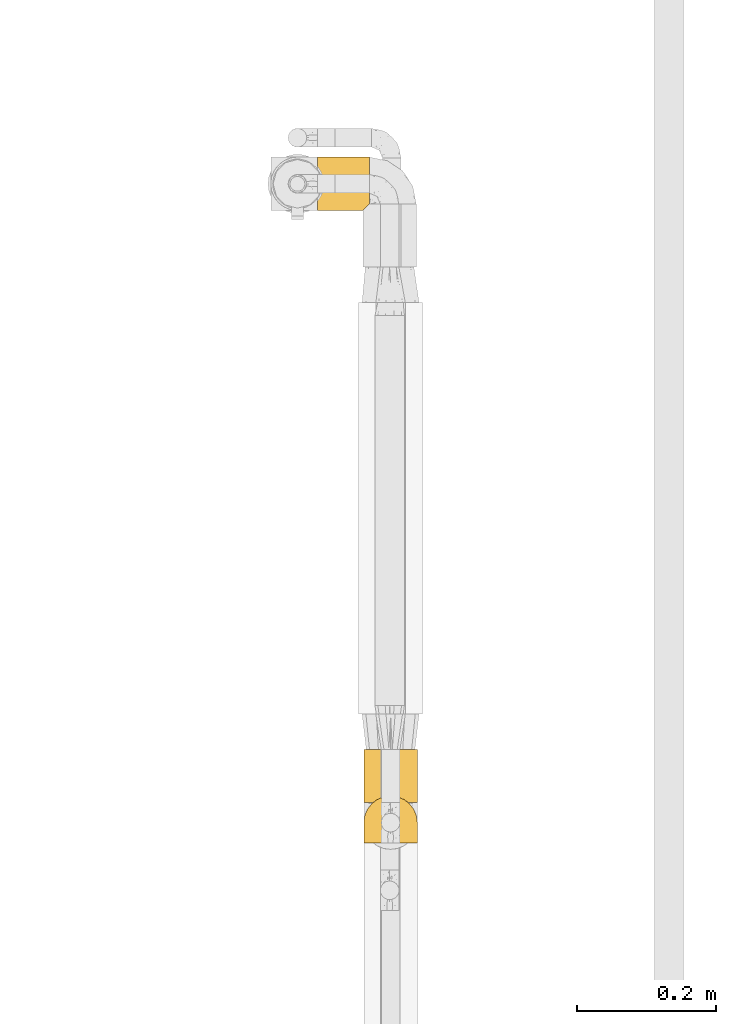
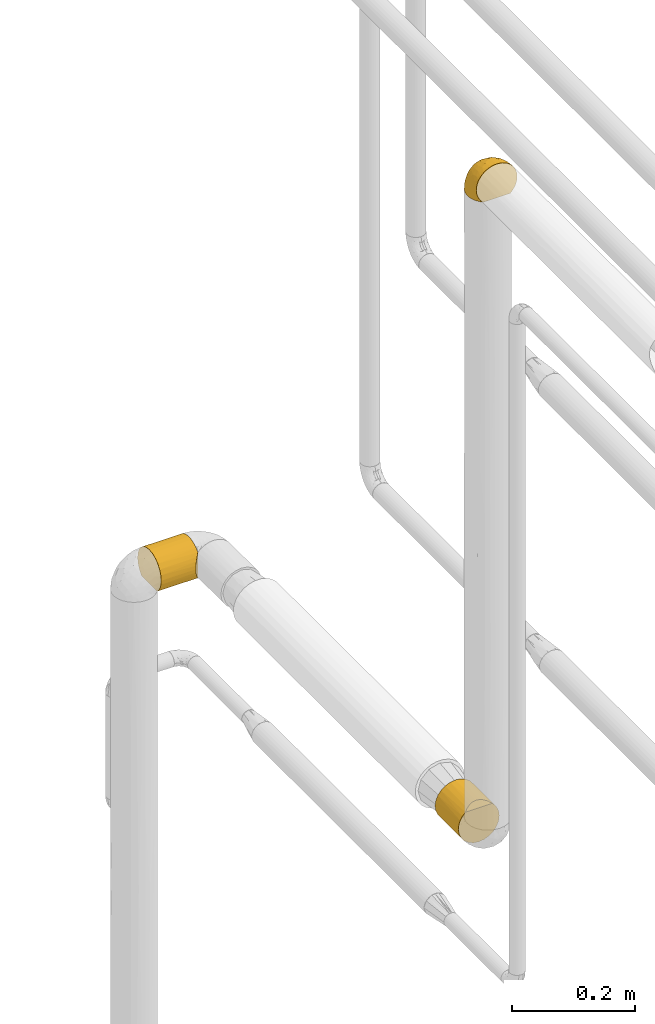
# One storey, part 65 of 827: 3 coverings.
"""IFC2X3 building model written with IfcOpenShell, lengths in millimetres."""

from ifc_helpers import new_model, entity, si_unit, converted_unit, derived_unit, direction, frame, origin, place, context, subcontext, project, spatial, faceted_brep, element, save


model = new_model("IFC2X3")

# Units and contexts
model_context = context("Model", 3, precision=0.01, world=origin(), true_north=direction((6.12303176911189e-17, 1.0)))
body_context = subcontext(model_context, "Body", "Model", "MODEL_VIEW")
ifc_project = project(units=[si_unit("LENGTHUNIT", "METRE", prefix="MILLI"), si_unit("AREAUNIT", "SQUARE_METRE"), si_unit("VOLUMEUNIT", "CUBIC_METRE"), converted_unit("PLANEANGLEUNIT", "DEGREE", entity("IfcRatioMeasure", 0.0174532925199433), si_unit("PLANEANGLEUNIT", "RADIAN"), dimensions=[0, 0, 0, 0, 0, 0, 0]), si_unit("MASSUNIT", "GRAM", prefix="KILO"), derived_unit("MASSDENSITYUNIT", [(si_unit("MASSUNIT", "GRAM", prefix="KILO"), 1), (si_unit("LENGTHUNIT", "METRE"), -3)]), derived_unit("MOMENTOFINERTIAUNIT", [(si_unit("LENGTHUNIT", "METRE"), 4)]), si_unit("TIMEUNIT", "SECOND"), si_unit("FREQUENCYUNIT", "HERTZ"), si_unit("THERMODYNAMICTEMPERATUREUNIT", "DEGREE_CELSIUS"), derived_unit("THERMALTRANSMITTANCEUNIT", [(si_unit("MASSUNIT", "GRAM", prefix="KILO"), 1), (si_unit("THERMODYNAMICTEMPERATUREUNIT", "KELVIN"), -1), (si_unit("TIMEUNIT", "SECOND"), -3)]), derived_unit("VOLUMETRICFLOWRATEUNIT", [(si_unit("LENGTHUNIT", "METRE"), 3), (si_unit("TIMEUNIT", "SECOND"), -1)]), derived_unit("MASSFLOWRATEUNIT", [(si_unit("MASSUNIT", "GRAM", prefix="KILO"), 1), (si_unit("TIMEUNIT", "SECOND"), -1)]), derived_unit("ROTATIONALFREQUENCYUNIT", [(si_unit("TIMEUNIT", "SECOND"), -1)]), si_unit("ELECTRICCURRENTUNIT", "AMPERE"), si_unit("ELECTRICVOLTAGEUNIT", "VOLT"), si_unit("POWERUNIT", "WATT"), si_unit("FORCEUNIT", "NEWTON", prefix="KILO"), si_unit("ILLUMINANCEUNIT", "LUX"), si_unit("LUMINOUSFLUXUNIT", "LUMEN"), si_unit("LUMINOUSINTENSITYUNIT", "CANDELA"), derived_unit("USERDEFINED", [(si_unit("MASSUNIT", "GRAM", prefix="KILO"), -1), (si_unit("LENGTHUNIT", "METRE"), -2), (si_unit("TIMEUNIT", "SECOND"), 3), (si_unit("LUMINOUSFLUXUNIT", "LUMEN"), 1)]), derived_unit("LINEARVELOCITYUNIT", [(si_unit("LENGTHUNIT", "METRE"), 1), (si_unit("TIMEUNIT", "SECOND"), -1)]), si_unit("PRESSUREUNIT", "PASCAL"), derived_unit("USERDEFINED", [(si_unit("LENGTHUNIT", "METRE"), -2), (si_unit("MASSUNIT", "GRAM", prefix="KILO"), 1), (si_unit("TIMEUNIT", "SECOND"), -2)]), derived_unit("LINEARFORCEUNIT", [(si_unit("MASSUNIT", "GRAM", prefix="KILO"), 1), (si_unit("LENGTHUNIT", "METRE"), 1), (si_unit("TIMEUNIT", "SECOND"), -2), (si_unit("LENGTHUNIT", "METRE"), -1)]), derived_unit("PLANARFORCEUNIT", [(si_unit("MASSUNIT", "GRAM", prefix="KILO"), 1), (si_unit("LENGTHUNIT", "METRE"), 1), (si_unit("TIMEUNIT", "SECOND"), -2), (si_unit("LENGTHUNIT", "METRE"), -2)])], contexts=[model_context])

# Site, building, storey
site_placement = place(None, origin())
site = spatial("IfcSite", under=ifc_project, at=site_placement, CompositionType="ELEMENT")
building_placement = place(site_placement, origin())
building = spatial("IfcBuilding", under=site, at=building_placement, CompositionType="ELEMENT")
storey_placement = place(building_placement, frame((0.0, 0.0, 28200.0)))
storey = spatial("IfcBuildingStorey", under=building, at=storey_placement, Name="08", CompositionType="ELEMENT", Elevation=28200.0)

# Coverings
covering_1_placement = place(storey_placement, frame((15160.93, 11287.8, 1505.75)))
element("IfcCovering", 1, at=covering_1_placement, inside=storey, Name=":ADSK_", ObjectType=":ADSK_", PredefinedType="INSULATION", context=body_context, shape_type="Brep", body=[
    faceted_brep([(20.8, 1.6, 6.74), (30.06, 1.6, 2.9), (40.0, 1.6, 1.6), (49.93, 1.6, 2.9), (59.2, 1.6, 6.74), (67.15, 1.6, 12.84), (73.25, 1.6, 20.8), (77.09, 1.6, 30.06), (78.4, 1.6, 40.0), (77.51, 1.6, 48.2), (74.9, 1.6, 56.01), (70.68, 1.6, 63.08), (65.05, 1.6, 69.1), (14.94, 1.6, 69.1), (9.31, 1.6, 63.08), (5.09, 1.6, 56.01), (2.48, 1.6, 48.2), (1.6, 1.6, 40.0), (2.9, 1.6, 30.06), (6.74, 1.6, 20.8), (12.84, 1.6, 12.84), (20.8, 77.5, 6.74), (12.84, 77.5, 12.84), (6.74, 77.5, 20.8), (2.9, 77.5, 30.06), (1.6, 77.5, 40.0), (2.9, 77.5, 49.93), (6.74, 77.5, 59.2), (12.84, 77.5, 67.15), (20.8, 77.5, 73.25), (30.06, 77.5, 77.09), (40.0, 77.5, 78.4), (49.93, 77.5, 77.09), (59.2, 77.5, 73.25), (67.15, 77.5, 67.15), (73.25, 77.5, 59.2), (77.09, 77.5, 49.93), (78.4, 77.5, 40.0), (77.09, 77.5, 30.06), (73.25, 77.5, 20.8), (67.15, 77.5, 12.84), (59.2, 77.5, 6.74), (49.93, 77.5, 2.9), (40.0, 77.5, 1.6), (30.06, 77.5, 2.9), (53.36, 8.5, 76.0), (46.78, 10.29, 77.79), (40.0, 10.9, 78.4), (59.51, 5.57, 73.07), (33.21, 10.29, 77.79), (26.63, 8.5, 76.0), (20.48, 5.57, 73.07)], [[[0, 1, 2, 3, 4, 5, 6, 7, 8, 9, 10, 11, 12, 13, 14, 15, 16, 17, 18, 19, 20]], [[21, 22, 23, 24, 25, 26, 27, 28, 29, 30, 31, 32, 33, 34, 35, 36, 37, 38, 39, 40, 41, 42, 43, 44]], [[24, 23, 19, 18]], [[25, 24, 18, 17]], [[20, 19, 23, 22]], [[1, 0, 21, 44]], [[2, 1, 44, 43]], [[22, 21, 0, 20]], [[3, 2, 43, 42]], [[4, 3, 42, 41]], [[41, 40, 5, 4]], [[7, 6, 39, 38]], [[8, 7, 38, 37]], [[40, 39, 6, 5]], [[9, 37, 36]], [[10, 36, 35]], [[11, 35, 34]], [[8, 37, 9]], [[9, 36, 10]], [[35, 11, 10]], [[34, 12, 11]], [[45, 33, 32]], [[32, 31, 46]], [[47, 46, 31]], [[48, 12, 33]], [[46, 45, 32]], [[48, 33, 45]], [[33, 12, 34]], [[49, 47, 31]], [[49, 31, 30]], [[50, 30, 29]], [[50, 49, 30]], [[13, 51, 29]], [[50, 29, 51]], [[29, 28, 13]], [[14, 28, 27]], [[15, 27, 26]], [[16, 26, 25]], [[14, 27, 15]], [[15, 26, 16]], [[25, 17, 16]], [[28, 14, 13]], [[45, 46, 47, 49, 50, 51, 13, 12, 48]]]),
])
covering_2_placement = place(storey_placement, frame((15094.48, 12139.43, 1505.75)))
element("IfcCovering", 2, at=covering_2_placement, inside=storey, Name=":ADSK_", ObjectType=":ADSK_", PredefinedType="INSULATION", context=body_context, shape_type="Brep", body=[
    faceted_brep([(1.6, 2.48, 31.79), (1.6, 1.6, 40.0), (1.6, 2.9, 49.93), (1.6, 6.74, 59.2), (1.6, 12.84, 67.15), (1.6, 20.8, 73.25), (1.6, 30.06, 77.09), (1.6, 40.0, 78.4), (1.6, 49.93, 77.09), (1.6, 59.2, 73.25), (1.6, 67.15, 67.15), (1.6, 73.25, 59.2), (1.6, 77.09, 49.93), (1.6, 78.4, 40.0), (1.6, 77.51, 31.79), (1.6, 74.9, 23.98), (1.6, 70.68, 16.91), (1.6, 65.05, 10.9), (1.6, 14.94, 10.9), (1.6, 9.31, 16.91), (1.6, 5.09, 23.98), (75.9, 10.9, 14.94), (75.9, 16.91, 9.31), (75.9, 23.98, 5.09), (75.9, 31.79, 2.48), (75.9, 40.0, 1.6), (75.9, 49.93, 2.9), (75.9, 59.2, 6.74), (75.9, 67.15, 12.84), (75.9, 73.25, 20.8), (75.9, 77.09, 30.06), (75.9, 78.4, 40.0), (75.9, 77.09, 49.93), (75.9, 73.25, 59.2), (75.9, 67.15, 67.15), (75.9, 59.2, 73.25), (75.9, 49.93, 77.09), (75.9, 40.0, 78.4), (75.9, 31.79, 77.51), (75.9, 23.98, 74.9), (75.9, 16.91, 70.68), (75.9, 10.9, 65.05), (8.5, 53.36, 4.0), (10.29, 46.78, 2.2), (10.9, 40.0, 1.6), (5.57, 59.51, 6.92), (10.29, 33.21, 2.2), (8.5, 26.63, 4.0), (5.57, 20.48, 6.92), (71.92, 6.92, 20.48), (69.0, 4.0, 26.63), (67.2, 2.2, 33.21), (66.6, 1.6, 40.0), (67.2, 2.2, 46.78), (69.0, 4.0, 53.36), (71.92, 6.92, 59.51)], [[[0, 1, 2, 3, 4, 5, 6, 7, 8, 9, 10, 11, 12, 13, 14, 15, 16, 17, 18, 19, 20]], [[21, 22, 23, 24, 25, 26, 27, 28, 29, 30, 31, 32, 33, 34, 35, 36, 37, 38, 39, 40, 41]], [[31, 30, 14]], [[29, 28, 16]], [[30, 29, 15]], [[13, 31, 14]], [[16, 15, 29]], [[30, 15, 14]], [[28, 17, 16]], [[42, 27, 26]], [[26, 25, 43]], [[44, 43, 25]], [[45, 17, 27]], [[43, 42, 26]], [[45, 27, 42]], [[27, 17, 28]], [[46, 25, 24]], [[47, 24, 23]], [[48, 23, 22]], [[46, 44, 25]], [[48, 47, 23]], [[18, 48, 22]], [[46, 24, 47]], [[22, 21, 18]], [[21, 49, 19]], [[50, 51, 0]], [[49, 50, 20]], [[19, 49, 20]], [[51, 1, 0]], [[0, 20, 50]], [[1, 51, 52]], [[21, 19, 18]], [[53, 54, 2]], [[55, 41, 3]], [[54, 55, 3]], [[52, 53, 1]], [[1, 53, 2]], [[54, 3, 2]], [[41, 4, 3]], [[5, 40, 39]], [[6, 39, 38]], [[7, 38, 37]], [[4, 40, 5]], [[5, 39, 6]], [[38, 7, 6]], [[40, 4, 41]], [[8, 7, 37, 36]], [[9, 8, 36, 35]], [[35, 34, 10, 9]], [[12, 11, 33, 32]], [[13, 12, 32, 31]], [[34, 33, 11, 10]], [[17, 45, 42, 43, 44, 46, 47, 48, 18]], [[51, 50, 49, 21, 41, 55, 54, 53, 52]]]),
])
covering_3_placement = place(storey_placement, frame((15160.88, 11229.61, 2819.46)))
element("IfcCovering", 3, at=covering_3_placement, inside=storey, Name=":ADSK_", ObjectType=":ADSK_", PredefinedType="INSULATION", context=body_context, shape_type="Brep", body=[
    faceted_brep([(74.68, 1.6, 47.38), (70.1, 1.6, 54.67), (64.01, 1.6, 60.76), (56.72, 1.6, 65.34), (48.6, 1.6, 68.18), (40.05, 1.6, 69.15), (31.49, 1.6, 68.18), (23.36, 1.6, 65.33), (16.07, 1.6, 60.75), (9.98, 1.6, 54.66), (5.4, 1.6, 47.37), (2.56, 1.6, 39.25), (1.6, 1.6, 30.7), (2.46, 1.6, 22.59), (5.01, 1.6, 14.86), (9.13, 1.6, 7.84), (14.62, 1.6, 1.85), (16.82, 1.6, 1.85), (18.56, 1.6, 1.85), (20.52, 1.6, 1.85), (22.49, 1.6, 1.85), (24.46, 1.6, 1.85), (26.42, 1.6, 1.85), (28.39, 1.6, 1.85), (30.36, 1.6, 1.85), (32.55, 1.6, 1.85), (34.75, 1.6, 1.85), (36.94, 1.6, 1.85), (39.13, 1.6, 1.85), (41.33, 1.6, 1.85), (43.52, 1.6, 1.85), (45.72, 1.6, 1.85), (47.91, 1.6, 1.85), (50.11, 1.6, 1.85), (52.3, 1.6, 1.85), (54.49, 1.6, 1.85), (56.69, 1.6, 1.85), (58.88, 1.6, 1.85), (61.08, 1.6, 1.85), (63.27, 1.6, 1.85), (65.47, 1.6, 1.85), (70.97, 1.6, 7.85), (75.09, 1.6, 14.88), (77.64, 1.6, 22.61), (78.5, 1.6, 30.7), (77.53, 1.6, 39.26), (14.62, 1.85, 1.6), (9.12, 7.85, 1.6), (5.0, 14.87, 1.6), (2.46, 22.6, 1.6), (1.6, 30.7, 1.6), (2.91, 40.65, 1.6), (6.75, 49.92, 1.6), (12.86, 57.89, 1.6), (20.82, 64.0, 1.6), (30.09, 67.84, 1.6), (40.05, 69.15, 1.6), (50.0, 67.84, 1.6), (59.27, 64.0, 1.6), (67.23, 57.89, 1.6), (73.34, 49.92, 1.6), (77.19, 40.65, 1.6), (78.5, 30.7, 1.6), (77.63, 22.6, 1.6), (75.09, 14.87, 1.6), (70.97, 7.85, 1.6), (65.47, 1.85, 1.6), (63.27, 1.85, 1.6), (62.29, 1.85, 1.6), (60.7, 1.85, 1.6), (59.11, 1.85, 1.6), (57.52, 1.85, 1.6), (55.93, 1.85, 1.6), (54.34, 1.85, 1.6), (52.76, 1.85, 1.6), (51.17, 1.85, 1.6), (49.58, 1.85, 1.6), (47.99, 1.85, 1.6), (46.4, 1.85, 1.6), (44.81, 1.85, 1.6), (43.22, 1.85, 1.6), (41.63, 1.85, 1.6), (40.05, 1.85, 1.6), (38.46, 1.85, 1.6), (36.87, 1.85, 1.6), (35.28, 1.85, 1.6), (33.69, 1.85, 1.6), (32.1, 1.85, 1.6), (30.51, 1.85, 1.6), (28.92, 1.85, 1.6), (27.33, 1.85, 1.6), (25.37, 1.85, 1.6), (23.4, 1.85, 1.6), (21.21, 1.85, 1.6), (19.01, 1.85, 1.6), (16.82, 1.85, 1.6), (42.32, 1.77, 1.78), (44.02, 1.78, 1.77), (47.13, 1.78, 1.78), (48.74, 1.78, 1.77), (23.57, 1.76, 1.79), (25.13, 1.77, 1.78), (61.34, 1.79, 1.76), (22.02, 1.78, 1.77), (29.72, 1.78, 1.77), (56.73, 1.79, 1.76), (55.14, 1.78, 1.77), (37.66, 1.78, 1.77), (64.12, 1.74, 1.8), (28.13, 1.79, 1.76), (26.62, 1.79, 1.77), (31.46, 1.77, 1.78), (16.16, 1.78, 1.77), (39.16, 1.79, 1.77), (50.37, 1.79, 1.76), (17.69, 1.78, 1.77), (19.17, 1.77, 1.78), (62.78, 1.78, 1.77), (58.35, 1.78, 1.77), (45.53, 1.79, 1.77), (59.91, 1.77, 1.78), (65.47, 1.78, 1.77), (65.47, 1.72, 1.8), (65.47, 1.67, 1.82), (14.62, 1.78, 1.77), (14.62, 1.8, 1.72), (14.62, 1.82, 1.66), (20.59, 1.79, 1.76), (32.99, 1.78, 1.77), (34.48, 1.79, 1.76), (51.91, 1.78, 1.77), (65.47, 1.82, 1.66), (65.47, 1.8, 1.72), (53.48, 1.77, 1.78), (14.62, 1.67, 1.82), (14.62, 1.72, 1.8), (40.77, 1.78, 1.77), (35.97, 1.77, 1.78), (7.84, 9.42, 3.72), (3.53, 17.65, 7.41), (8.32, 7.42, 6.13), (2.19, 15.21, 19.34), (3.53, 7.41, 17.64), (1.6, 16.15, 26.8), (1.6, 28.75, 8.87), (4.57, 13.67, 9.2), (3.96, 12.79, 12.79), (2.28, 19.18, 14.62), (7.69, 9.05, 5.33), (8.32, 5.74, 7.7), (7.84, 3.72, 9.41), (1.6, 8.87, 28.75), (1.6, 21.47, 21.47), (1.6, 26.8, 16.15), (4.34, 9.54, 14.14), (1.6, 7.34, 29.16), (29.63, 37.63, 57.03), (27.34, 17.92, 64.92), (40.05, 27.45, 64.0), (2.45, 37.26, 11.99), (4.52, 44.75, 9.2), (4.52, 42.08, 18.36), (7.49, 21.49, 46.98), (7.49, 11.02, 50.24), (12.85, 15.64, 56.1), (19.99, 45.26, 45.49), (16.37, 35.21, 50.57), (22.67, 36.59, 54.46), (32.9, 65.5, 21.34), (25.33, 64.0, 18.4), (40.05, 15.2, 66.44), (16.64, 60.27, 12.07), (9.54, 52.32, 15.19), (2.35, 26.03, 28.97), (2.43, 34.22, 19.16), (3.26, 22.53, 36.04), (3.75, 12.03, 42.07), (19.58, 13.32, 62.12), (7.5, 35.9, 37.37), (9.07, 45.87, 28.65), (4.04, 33.87, 29.39), (13.94, 25.74, 53.59), (19.58, 26.34, 58.06), (28.21, 46.78, 49.27), (24.75, 59.55, 29.63), (31.42, 60.18, 33.21), (16.64, 56.57, 24.62), (26.2, 53.93, 40.1), (33.36, 53.36, 44.08), (40.05, 49.36, 49.36), (40.05, 38.4, 56.68), (40.05, 66.44, 15.2), (16.14, 50.09, 35.57), (12.85, 41.08, 41.71), (10.47, 31.14, 46.4), (6.49, 28.19, 41.41), (40.05, 64.01, 27.45), (40.05, 56.68, 38.4), (76.05, 33.87, 29.38), (72.59, 35.89, 37.39), (73.58, 28.19, 41.44), (47.19, 65.5, 21.34), (55.35, 59.54, 29.64), (54.76, 64.0, 18.41), (63.45, 56.57, 24.63), (63.45, 60.27, 12.08), (70.55, 52.32, 15.19), (46.73, 53.36, 44.08), (51.87, 46.77, 49.28), (53.88, 53.92, 40.11), (72.6, 21.48, 46.99), (72.6, 11.01, 50.26), (76.34, 12.03, 42.08), (60.09, 45.25, 45.5), (63.95, 50.09, 35.59), (78.5, 28.75, 8.87), (77.64, 37.26, 11.99), (77.66, 34.22, 19.16), (78.5, 7.34, 29.16), (75.57, 42.08, 18.36), (75.57, 44.75, 9.2), (50.46, 37.61, 57.04), (52.74, 17.91, 64.92), (60.5, 26.34, 58.08), (60.5, 13.31, 62.13), (67.23, 15.64, 56.11), (78.5, 26.8, 16.15), (67.23, 41.07, 41.73), (63.7, 35.21, 50.58), (69.61, 31.13, 46.42), (76.82, 22.54, 36.05), (78.5, 16.15, 26.8), (71.01, 45.87, 28.67), (66.14, 25.73, 53.61), (78.5, 8.87, 28.75), (48.67, 60.18, 33.21), (77.74, 26.03, 28.97), (78.5, 21.47, 21.47), (57.37, 37.65, 53.78), (76.57, 17.65, 7.41), (73.21, 11.06, 3.51), (71.93, 8.56, 4.68), (71.07, 6.63, 5.52), (75.09, 12.78, 8.75), (76.13, 12.79, 12.79), (76.57, 7.42, 17.65), (77.69, 18.97, 13.9), (72.26, 3.73, 9.42), (71.77, 5.77, 7.68), (77.9, 15.21, 19.34), (75.75, 9.52, 14.13)], [[[0, 1, 2, 3, 4, 5, 6, 7, 8, 9, 10, 11, 12, 13, 14, 15, 16, 17, 18, 19, 20, 21, 22, 23, 24, 25, 26, 27, 28, 29, 30, 31, 32, 33, 34, 35, 36, 37, 38, 39, 40, 41, 42, 43, 44, 45]], [[46, 47, 48, 49, 50, 51, 52, 53, 54, 55, 56, 57, 58, 59, 60, 61, 62, 63, 64, 65, 66, 67, 68, 69, 70, 71, 72, 73, 74, 75, 76, 77, 78, 79, 80, 81, 82, 83, 84, 85, 86, 87, 88, 89, 90, 91, 92, 93, 94, 95]], [[96, 97, 30]], [[98, 77, 99]], [[100, 101, 21]], [[69, 68, 102]], [[20, 19, 103]], [[24, 23, 104]], [[20, 103, 100]], [[72, 105, 106]], [[84, 83, 107]], [[89, 88, 104]], [[108, 67, 66]], [[109, 110, 90]], [[111, 25, 24]], [[112, 17, 16]], [[82, 113, 83]], [[109, 23, 22]], [[114, 76, 75]], [[105, 36, 106]], [[104, 111, 24]], [[18, 115, 116]], [[97, 96, 80]], [[67, 108, 117]], [[105, 71, 118]], [[31, 97, 119]], [[102, 120, 69]], [[108, 121, 122, 123, 40]], [[112, 95, 115]], [[17, 115, 18]], [[94, 116, 115]], [[117, 68, 67]], [[38, 117, 39]], [[112, 124, 125, 126, 46]], [[17, 112, 115]], [[70, 120, 118]], [[39, 117, 108]], [[120, 38, 37]], [[120, 37, 118]], [[120, 70, 69]], [[116, 94, 127]], [[128, 86, 129]], [[117, 38, 102]], [[74, 130, 75]], [[99, 33, 32]], [[115, 95, 94]], [[39, 108, 40]], [[108, 66, 131, 132, 121]], [[105, 72, 71]], [[118, 37, 36]], [[71, 70, 118]], [[35, 106, 36]], [[36, 105, 118]], [[35, 133, 106]], [[74, 73, 133]], [[106, 133, 73]], [[99, 114, 33]], [[133, 35, 34]], [[73, 72, 106]], [[95, 112, 46]], [[112, 16, 134, 135, 124]], [[130, 114, 75]], [[99, 76, 114]], [[114, 130, 33]], [[34, 33, 130]], [[78, 77, 98]], [[98, 119, 78]], [[130, 133, 34]], [[133, 130, 74]], [[79, 97, 80]], [[98, 99, 32]], [[98, 32, 31]], [[77, 76, 99]], [[97, 79, 119]], [[136, 96, 29]], [[30, 97, 31]], [[136, 29, 28]], [[81, 80, 96]], [[29, 96, 30]], [[31, 119, 98]], [[119, 79, 78]], [[96, 136, 81]], [[82, 81, 136]], [[113, 107, 83]], [[84, 107, 137]], [[107, 27, 137]], [[113, 28, 107]], [[27, 107, 28]], [[85, 84, 137]], [[137, 27, 26]], [[113, 136, 28]], [[136, 113, 82]], [[109, 89, 104]], [[86, 85, 129]], [[89, 109, 90]], [[111, 87, 128]], [[26, 129, 137]], [[88, 111, 104]], [[25, 111, 128]], [[22, 110, 109]], [[23, 109, 104]], [[110, 91, 90]], [[100, 92, 101]], [[110, 22, 101]], [[91, 110, 101]], [[116, 19, 18]], [[111, 88, 87]], [[127, 103, 19]], [[25, 128, 26]], [[86, 128, 87]], [[128, 129, 26]], [[137, 129, 85]], [[120, 102, 38]], [[117, 102, 68]], [[91, 101, 92]], [[21, 101, 22]], [[93, 92, 103]], [[100, 21, 20]], [[100, 103, 92]], [[127, 93, 103]], [[93, 127, 94]], [[116, 127, 19]], [[126, 138, 47]], [[48, 138, 139]], [[140, 125, 124]], [[141, 142, 143]], [[144, 49, 139]], [[145, 140, 146]], [[48, 139, 49]], [[139, 145, 147]], [[144, 50, 49]], [[126, 125, 148]], [[14, 13, 142]], [[149, 146, 140]], [[148, 140, 145]], [[150, 149, 135]], [[150, 14, 142]], [[16, 15, 134]], [[13, 151, 142]], [[124, 149, 140]], [[141, 143, 152]], [[14, 150, 15]], [[15, 150, 134]], [[47, 46, 126]], [[139, 153, 144]], [[138, 48, 47]], [[125, 140, 148]], [[135, 134, 150]], [[146, 154, 141]], [[145, 146, 147]], [[148, 139, 138]], [[147, 152, 153]], [[147, 146, 141]], [[139, 147, 153]], [[139, 148, 145]], [[148, 138, 126]], [[147, 141, 152]], [[146, 149, 154]], [[150, 154, 149]], [[142, 141, 154]], [[13, 12, 155, 151]], [[151, 143, 142]], [[150, 142, 154]], [[149, 124, 135]], [[156, 157, 158]], [[50, 144, 159]], [[160, 52, 51]], [[159, 161, 160]], [[162, 163, 164]], [[165, 166, 167]], [[155, 12, 11]], [[157, 156, 167]], [[168, 55, 169]], [[157, 6, 170]], [[171, 54, 53]], [[172, 53, 52]], [[54, 169, 55]], [[54, 171, 169]], [[172, 52, 160]], [[152, 173, 174]], [[175, 143, 176]], [[155, 11, 176]], [[8, 7, 177]], [[164, 9, 8]], [[176, 143, 151, 155]], [[176, 11, 10]], [[163, 176, 10]], [[178, 179, 180]], [[176, 162, 175]], [[181, 182, 166]], [[181, 164, 182]], [[165, 167, 183]], [[168, 184, 185]], [[157, 7, 6]], [[158, 157, 170]], [[182, 177, 157]], [[186, 172, 179]], [[177, 164, 8]], [[187, 188, 185]], [[9, 163, 10]], [[179, 172, 161]], [[189, 156, 158, 190]], [[144, 174, 159]], [[171, 172, 186]], [[184, 187, 185]], [[55, 168, 191]], [[165, 192, 193]], [[174, 173, 180]], [[162, 194, 195]], [[175, 180, 173]], [[6, 5, 170]], [[157, 177, 7]], [[164, 177, 182]], [[164, 163, 9]], [[176, 163, 162]], [[180, 179, 161]], [[179, 193, 192]], [[174, 161, 159]], [[194, 178, 195]], [[191, 168, 196]], [[191, 56, 55]], [[188, 189, 197]], [[197, 196, 185]], [[168, 185, 196]], [[183, 188, 187]], [[197, 185, 188]], [[184, 168, 169]], [[169, 186, 184]], [[192, 184, 186]], [[165, 183, 187]], [[183, 156, 189]], [[187, 184, 192]], [[166, 165, 193]], [[187, 192, 165]], [[179, 192, 186]], [[194, 166, 193]], [[167, 166, 182]], [[178, 194, 193]], [[181, 162, 164]], [[179, 178, 193]], [[195, 180, 175]], [[157, 167, 182]], [[167, 156, 183]], [[166, 194, 181]], [[162, 181, 194]], [[180, 195, 178]], [[175, 173, 143]], [[175, 162, 195]], [[172, 171, 53]], [[169, 171, 186]], [[51, 50, 159]], [[172, 160, 161]], [[51, 159, 160]], [[174, 144, 153]], [[152, 174, 153]], [[180, 161, 174]], [[189, 188, 183]], [[143, 173, 152]], [[198, 199, 200]], [[196, 201, 191]], [[201, 202, 203]], [[203, 204, 205]], [[206, 60, 59]], [[207, 208, 209]], [[210, 211, 212]], [[213, 214, 209]], [[215, 216, 217]], [[45, 218, 212]], [[206, 219, 220]], [[45, 44, 218]], [[61, 220, 216]], [[220, 61, 60]], [[0, 45, 212]], [[58, 57, 203]], [[221, 158, 222]], [[205, 206, 59]], [[223, 224, 225]], [[1, 225, 2]], [[58, 205, 59]], [[222, 3, 224]], [[222, 170, 4]], [[1, 0, 211]], [[225, 224, 2]], [[217, 226, 215]], [[227, 228, 229]], [[210, 212, 230]], [[212, 231, 230]], [[3, 222, 4]], [[206, 232, 219]], [[211, 225, 1]], [[221, 222, 223]], [[210, 229, 233]], [[228, 227, 213]], [[3, 2, 224]], [[221, 189, 190, 158]], [[212, 218, 234, 231]], [[61, 216, 62]], [[204, 214, 232]], [[57, 191, 201]], [[201, 235, 202]], [[196, 197, 235]], [[209, 208, 213]], [[236, 231, 237]], [[198, 219, 232]], [[170, 222, 158]], [[170, 5, 4]], [[222, 224, 223]], [[212, 211, 0]], [[225, 211, 210]], [[204, 232, 206]], [[229, 199, 227]], [[199, 232, 227]], [[230, 236, 198]], [[57, 56, 191]], [[207, 235, 197]], [[57, 201, 203]], [[208, 207, 189]], [[189, 207, 197]], [[235, 207, 209]], [[235, 209, 202]], [[235, 201, 196]], [[214, 202, 209]], [[204, 203, 202]], [[231, 236, 230]], [[228, 238, 223]], [[208, 221, 238]], [[214, 213, 227]], [[238, 228, 213]], [[223, 225, 233]], [[233, 228, 223]], [[200, 199, 229]], [[229, 210, 200]], [[232, 199, 198]], [[232, 214, 227]], [[214, 204, 202]], [[208, 238, 213]], [[223, 238, 221]], [[210, 233, 225]], [[229, 228, 233]], [[210, 230, 200]], [[217, 237, 226]], [[198, 200, 230]], [[203, 205, 58]], [[206, 205, 204]], [[206, 220, 60]], [[216, 220, 219]], [[216, 219, 217]], [[216, 215, 62]], [[219, 198, 217]], [[217, 198, 236]], [[189, 221, 208]], [[217, 236, 237]], [[63, 215, 239]], [[215, 226, 239]], [[215, 63, 62]], [[240, 239, 241]], [[241, 132, 131]], [[239, 240, 64]], [[242, 243, 244]], [[63, 239, 64]], [[131, 66, 65]], [[240, 131, 65]], [[245, 234, 43]], [[240, 65, 64]], [[242, 121, 132]], [[42, 245, 43]], [[244, 243, 246]], [[41, 123, 247]], [[43, 234, 218, 44]], [[247, 122, 248]], [[237, 249, 246]], [[248, 244, 250]], [[121, 242, 248]], [[41, 40, 123]], [[132, 241, 242]], [[247, 42, 41]], [[131, 240, 241]], [[243, 242, 241]], [[248, 242, 244]], [[250, 244, 249]], [[250, 247, 248]], [[241, 239, 243]], [[246, 239, 226]], [[239, 246, 243]], [[249, 244, 246]], [[246, 226, 237]], [[231, 245, 249]], [[237, 231, 249]], [[249, 245, 250]], [[247, 250, 245]], [[245, 231, 234]], [[42, 247, 245]], [[122, 247, 123]], [[122, 121, 248]]]),
])

save(model, "model.ifc")
